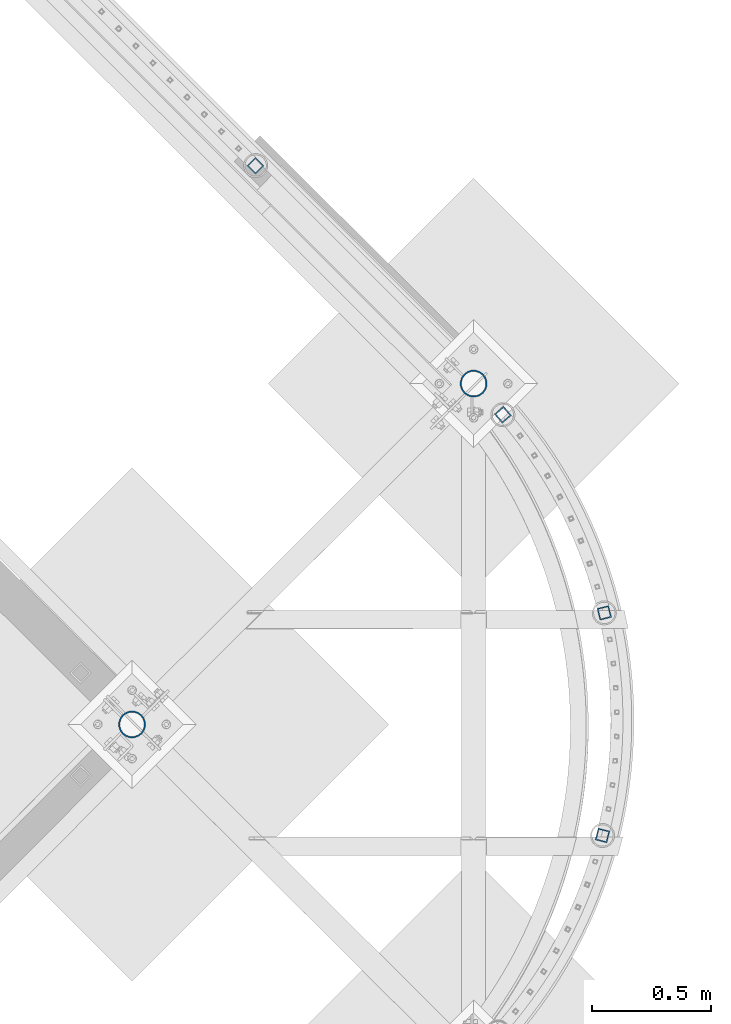
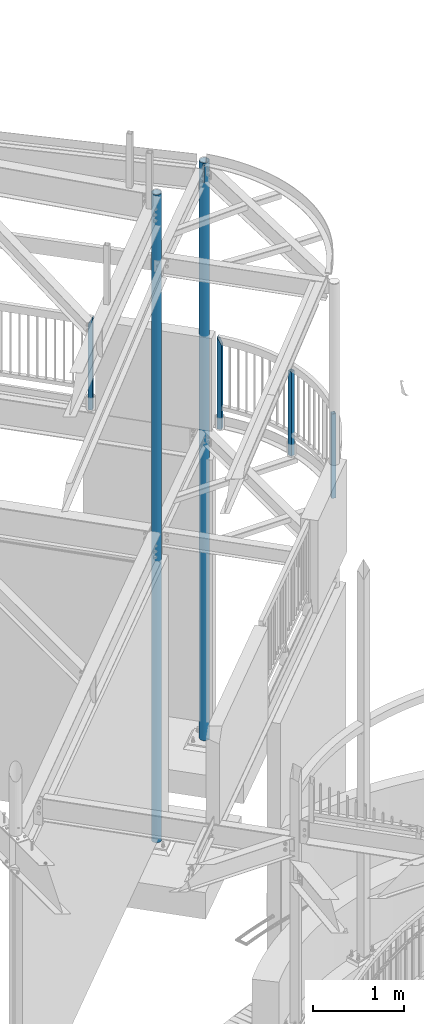
# One storey, part 137 of 975: 6 columns.
"""IFC2X3 building model written with IfcOpenShell, lengths in millimetres."""

from ifc_helpers import new_model, si_unit, frame, origin_with_axes, place, context, subcontext, project, spatial, faceted_brep, material, type_object, element, save


model = new_model("IFC2X3")

# Units and contexts
model_context = context("Model", 3, precision=1e-05, world=origin_with_axes())
body_context = subcontext(model_context, "Body", "Model", "MODEL_VIEW")
ifc_project = project(units=[si_unit("LENGTHUNIT", "METRE", prefix="MILLI"), si_unit("AREAUNIT", "SQUARE_METRE"), si_unit("VOLUMEUNIT", "CUBIC_METRE"), si_unit("MASSUNIT", "GRAM", prefix="KILO"), si_unit("TIMEUNIT", "SECOND"), si_unit("PLANEANGLEUNIT", "RADIAN"), si_unit("SOLIDANGLEUNIT", "STERADIAN"), si_unit("THERMODYNAMICTEMPERATUREUNIT", "DEGREE_CELSIUS"), si_unit("LUMINOUSINTENSITYUNIT", "LUMEN")], contexts=[model_context])

# Site, building, storey
site_placement = place(None, origin_with_axes())
site = spatial("IfcSite", under=ifc_project, at=site_placement, CompositionType="ELEMENT")
building_placement = place(site_placement, origin_with_axes())
building = spatial("IfcBuilding", under=site, at=building_placement, Name="Undefined", CompositionType="ELEMENT")
storey_placement = place(building_placement, origin_with_axes())
storey = spatial("IfcBuildingStorey", under=building, at=storey_placement, Name="Undefined", CompositionType="ELEMENT", Elevation=0.0)

# Columns
ifc_material_1 = material()
column_type_1 = type_object("IfcColumnType", Name="HSS2X2X.188_TUBES", PredefinedType="NOTDEFINED")
for number, where, z_axis, x_axis, name in (
    (1, (36078.7761034097, 11200.4077223262, 3946.52499999334), (0.969531343145851, -0.244967293036851, 0.0), (0.0, 0.0, 1.0), "HANDRAIL"),
    (2, (36086.125656387, 12134.6039135276, 3946.52499999334), (0.968966441574155, 0.247192303891364, 0.0), (0.0, 0.0, 1.0), "HANDRAIL"),
):
    element("IfcColumn", number, at=place(storey_placement, frame(where, z_axis=z_axis, x_axis=x_axis)), inside=storey, type_object=column_type_1, material=ifc_material_1, Name=name, ObjectType="HSS2X2X.188_TUBES", context=body_context, shape_type="Brep", body=[
        faceted_brep([(0.0, 20.6374999999753, -20.6375000000298), (0.0, -20.6375000000153, -20.6375000000153), (1133.47498819963, -20.6374999995132, -20.6374999998079), (1133.47498823965, 20.6375000004919, -20.6374999998552), (0.0, -20.6374999999825, 20.6375000000335), (1133.47498818942, -20.6374999995242, 20.6375000001026), (0.0, 20.6375000000116, 20.6375000000189), (1133.47498822943, 20.6375000004846, 20.6375000000626), (0.0, 25.3999999999724, -25.4000000000342), (0.0, 25.400000000016, 25.4000000000196), (1133.47498823287, 25.4000000004817, 25.4000000000487), (1133.47498824544, 25.4000000004926, -25.3999999998487), (0.0, -25.399999999976, 25.4000000000378), (1133.47498818362, -25.3999999995285, 25.4000000000997), (0.0, -25.400000000016, -25.4000000000196), (1133.47498819619, -25.399999999514, -25.3999999997941)], [[[0, 1, 2, 3]], [[1, 4, 5, 2]], [[4, 6, 7, 5]], [[6, 0, 3, 7]], [[8, 9, 10, 11]], [[9, 12, 13, 10]], [[12, 14, 15, 13]], [[14, 8, 11, 15]], [[13, 15, 11, 10], [5, 7, 3, 2]], [[14, 12, 9, 8], [6, 4, 1, 0]]]),
    ])
column_1_placement = place(storey_placement, frame((35660.5273593798, 12966.2522543199, 3946.52499999334), z_axis=(0.759945520097653, 0.649986774083525, 0.0), x_axis=(0.0, 0.0, 1.0)))
element("IfcColumn", 3, at=column_1_placement, inside=storey, type_object=column_type_1, material=ifc_material_1, Name="HANDRAIL", ObjectType="HSS2X2X.188_TUBES", context=body_context, shape_type="Brep", body=[
    faceted_brep([(0.0, 20.6374999999753, -20.6375000000298), (0.0, -20.6375000000153, -20.6375000000153), (1225.54998821705, -20.6375000000317, -20.6375000000407), (1143.46249827633, 20.6375000000389, -20.6374999999753), (0.0, -20.6374999999825, 20.6375000000335), (1225.08747823559, -20.6375000000371, 20.6374999999825), (0.0, 20.6375000000116, 20.6375000000189), (1142.99998829488, 20.6375000000335, 20.637500000048), (0.0, 25.3999999999724, -25.4000000000342), (0.0, 25.400000000016, 25.4000000000196), (1133.47498823287, 25.4000000004817, 25.4000000000487), (1134.04423135796, 25.4000000000506, -25.3999999999796), (0.0, -25.399999999976, 25.4000000000378), (1234.50574515396, -25.4000000000451, 25.3999999999724), (0.0, -25.400000000016, -25.4000000000196), (1235.07498820807, -25.4000000000397, -25.4000000000597)], [[[0, 1, 2, 3]], [[1, 4, 5, 2]], [[4, 6, 7, 5]], [[6, 0, 3, 7]], [[8, 9, 10, 11]], [[9, 12, 13, 10]], [[12, 14, 15, 13]], [[14, 8, 11, 15]], [[13, 15, 11, 10], [5, 7, 3, 2]], [[14, 12, 9, 8], [6, 4, 1, 0]]]),
])
column_2_placement = place(storey_placement, frame((34622.8180044815, 14011.4024796212, 3937.00001179213), z_axis=(-0.707106781186601, 0.707106781186494, 2.36468622460961e-14), x_axis=(0.0, 0.0, 1.0)))
element("IfcColumn", 4, at=column_2_placement, inside=storey, type_object=column_type_1, material=ifc_material_1, Name="HANDRAIL", ObjectType="HSS2X2X.188_TUBES", context=body_context, shape_type="Brep", body=[
    faceted_brep([(0.0, 20.6374999999753, -20.6375000000298), (0.0, -20.6375000000153, -20.6375000000153), (1235.074979717, -20.6374999999462, -20.6374999999462), (1235.07091767483, 20.6374999999871, -20.6375000000007), (0.0, -20.6374999999825, 20.6375000000335), (1152.52905859553, -20.6375000000121, 20.6375000000007), (0.0, 20.6375000000116, 20.6375000000189), (1152.52497980387, 20.6374999999534, 20.6374999999534), (0.0, 25.3999999999724, -25.4000000000342), (0.0, 25.400000000016, 25.4000000000196), (1143.0, 25.4000000000051, 25.4000000000378), (1244.59503672188, 25.399999999936, -25.3999999999396), (0.0, -25.399999999976, 25.4000000000378), (1143.00493968616, -25.399999999936, 25.399999999936), (0.0, -25.400000000016, -25.4000000000196), (1244.59997970698, -25.399999999936, -25.399999999936)], [[[0, 1, 2, 3]], [[1, 4, 5, 2]], [[4, 6, 7, 5]], [[6, 0, 3, 7]], [[8, 9, 10, 11]], [[9, 12, 13, 10]], [[12, 14, 15, 13]], [[14, 8, 11, 15]], [[13, 15, 11, 10], [5, 7, 3, 2]], [[14, 12, 9, 8], [6, 4, 1, 0]]]),
])
ifc_material_2 = material(Name="STEEL/A53")
column_type_2 = type_object("IfcColumnType", Name="PIPE4STD", PredefinedType="NOTDEFINED")
column_3_placement = place(storey_placement, frame((35537.7749999864, 13096.8750002687, -266.7), z_axis=(-0.707106781186601, 0.707106781186494, 2.36468622460961e-14), x_axis=(0.0, 0.0, 1.0)))
element("IfcColumn", 5, at=column_3_placement, inside=storey, type_object=column_type_2, material=ifc_material_2, Name="COLUMN", ObjectType="PIPE4STD", context=body_context, shape_type="Brep", body=[
    faceted_brep([(7761.2875, -55.0200580201781, -13.4479244010545), (7761.2875, -49.0002580201399, -13.4479244013128), (7513.6375, -49.0002580201399, -13.4479244013128), (7513.6375, -55.0200580201781, -13.4479244010545), (7513.6375, -51.0117393045148, -0.747931395271735), (7513.6375, -57.0315393080673, -0.747931372819949), (7761.2875, -51.0117393045148, -0.747931395271735), (7761.2875, -57.0315393080673, -0.747931372819949), (7761.2875, 49.0002580194123, -13.4479244055565), (7761.2875, 55.0200580193632, -13.4479244058148), (7513.6375, 55.0200580193632, -13.4479244058148), (7513.6375, 49.0002580194123, -13.4479244055565), (7513.6375, 57.0315392406483, -0.747931798301579), (7513.6375, 51.0117392442116, -0.747931775846155), (7761.2875, 57.0315392406483, -0.747931798301579), (7761.2875, 51.0117392442116, -0.747931775846155), (19.0500000000025, 57.1499999999996, 0.0), (19.0500000000025, 54.3528799062678, 17.6603212285299), (7775.575, 54.3528799062333, 17.6603212285772), (7775.575, 57.149999999936, 7.45785655453801e-11), (19.0500000000025, 46.2353212285279, 33.5919271685161), (7775.575, 46.2353212285161, 33.5919271685379), (19.0500000000025, 33.5919271685152, 46.235321228527), (7775.575, 33.5919271685343, 46.2353212285198), (19.0500000000025, 17.6603212285281, 54.3528799062697), (7775.575, 17.66032122857, 54.3528799062333), (19.0500000000025, 0.0, 57.1500000000015), (7775.575, 7.27595761418343e-11, 57.1499999999378), (19.0500000000025, -17.6603212285281, 54.3528799062697), (7775.575, -17.660321228439, 54.352879906186), (19.0500000000025, -33.5919271685152, 46.235321228527), (7775.575, -33.5919271684179, 46.2353212284324), (19.0500000000025, -46.2353212285279, 33.5919271685161), (7775.575, -46.2353212284361, 33.5919271684161), (19.0500000000025, -54.3528799062678, 17.6603212285299), (7775.575, -54.3528799061896, 17.660321228439), (19.0500000000025, -57.1499999999996, 0.0), (7775.575, -57.149999999936, -7.27595761418343e-11), (19.0500000000025, 46.2353212285279, -33.5919271685161), (19.0500000000025, 54.3528799062678, -17.6603212285299), (7775.575, 54.3528799061824, -17.6603212284354), (7775.575, 46.2353212284288, -33.5919271684143), (19.0500000000025, 33.5919271685152, -46.235321228527), (7775.575, 33.5919271684106, -46.2353212284306), (19.0500000000025, 17.6603212285281, -54.3528799062697), (7775.575, 17.6603212284317, -54.3528799061824), (19.0500000000025, 0.0, -57.1500000000015), (7775.575, -7.27595761418343e-11, -57.149999999936), (19.0500000000025, -17.6603212285281, -54.3528799062697), (7775.575, -17.6603212285772, -54.3528799062315), (19.0500000000025, -33.5919271685152, -46.235321228527), (7775.575, -33.5919271685416, -46.2353212285179), (19.0500000000025, -46.2353212285279, -33.5919271685161), (7775.575, -46.2353212285234, -33.5919271685361), (19.0500000000025, -54.3528799062678, -17.6603212285299), (7775.575, -54.3528799062333, -17.6603212285754), (19.0500000000025, -48.6277098894743, -15.8001007257917), (19.0500000000025, -41.3652007257897, -30.0535775067656), (19.0500000000025, -30.0535775067647, -41.3652007257915), (19.0500000000025, -15.8001007257899, -48.6277098894752), (19.0500000000025, 0.0, -51.1301999999996), (19.0500000000025, 15.8001007257899, -48.6277098894752), (19.0500000000025, 30.0535775067647, -41.3652007257915), (19.0500000000025, 41.3652007257897, -30.0535775067656), (19.0500000000025, 48.6277098894743, -15.8001007257917), (19.0500000000025, 51.1301999999996, 0.0), (19.0500000000025, 48.6277098894743, 15.8001007257917), (19.0500000000025, 41.3652007257897, 30.0535775067656), (19.0500000000025, 30.0535775067647, 41.3652007257915), (19.0500000000025, 15.8001007257899, 48.6277098894752), (19.0500000000025, 0.0, 51.1301999999996), (19.0500000000025, -15.8001007257899, 48.6277098894752), (19.0500000000025, -30.0535775067647, 41.3652007257915), (19.0500000000025, -41.3652007257897, 30.0535775067656), (19.0500000000025, -48.6277098894743, 15.8001007257917), (19.0500000000025, -51.1301999999996, 0.0), (7775.575, -51.1301999999414, -6.3664629124105e-11), (7775.575, -48.6277098894425, -15.8001007258372), (7775.575, -41.3652007257842, -30.0535775067856), (7775.575, -30.053577506791, -41.3652007257788), (7775.575, -15.8001007258426, -48.627709889437), (7775.575, -7.27595761418343e-11, -51.1301999999396), (7775.575, 15.8001007257044, -48.6277098893952), (7775.575, 30.0535775066746, -41.365200725706), (7775.575, 41.3652007257042, -30.0535775066783), (7775.575, 48.6277098893916, -15.8001007257044), (7775.575, 51.1301999999414, 6.73026079311967e-11), (7775.575, 48.6277098894352, 15.800100725839), (7775.575, 41.365200725777, 30.0535775067874), (7775.575, 30.0535775067838, 41.3652007257806), (7775.575, 15.8001007258354, 48.6277098894388), (7775.575, 6.54836185276508e-11, 51.1301999999432), (7775.575, -15.8001007257117, 48.6277098894025), (7775.575, -30.0535775066819, 41.3652007257078), (7775.575, -41.3652007257115, 30.0535775066801), (7775.575, -48.6277098893988, 15.8001007257117)], [[[0, 1, 2, 3]], [[3, 2, 4, 5]], [[5, 4, 6, 7]], [[7, 6, 1, 0]], [[8, 9, 10, 11]], [[11, 10, 12, 13]], [[13, 12, 14, 15]], [[15, 14, 9, 8]], [[16, 17, 18, 19]], [[17, 20, 21, 18]], [[20, 22, 23, 21]], [[22, 24, 25, 23]], [[24, 26, 27, 25]], [[26, 28, 29, 27]], [[28, 30, 31, 29]], [[30, 32, 33, 31]], [[32, 34, 35, 33]], [[34, 36, 37, 35]], [[38, 39, 40, 41]], [[42, 38, 41, 43]], [[44, 42, 43, 45]], [[46, 44, 45, 47]], [[48, 46, 47, 49]], [[50, 48, 49, 51]], [[52, 50, 51, 53]], [[54, 52, 53, 55]], [[36, 54, 55, 37], [3, 5, 7, 0]], [[34, 32, 30, 28, 26, 24, 22, 20, 17, 16, 39, 38, 42, 44, 46, 48, 50, 52, 54, 36], [56, 57, 58, 59, 60, 61, 62, 63, 64, 65, 66, 67, 68, 69, 70, 71, 72, 73, 74, 75]], [[56, 75, 76, 77], [2, 1, 6, 4]], [[57, 56, 77, 78]], [[58, 57, 78, 79]], [[59, 58, 79, 80]], [[60, 59, 80, 81]], [[61, 60, 81, 82]], [[62, 61, 82, 83]], [[63, 62, 83, 84]], [[64, 63, 84, 85]], [[65, 64, 85, 86], [11, 13, 15, 8]], [[66, 65, 86, 87]], [[67, 66, 87, 88]], [[68, 67, 88, 89]], [[69, 68, 89, 90]], [[70, 69, 90, 91]], [[71, 70, 91, 92]], [[72, 71, 92, 93]], [[73, 72, 93, 94]], [[74, 73, 94, 95]], [[75, 74, 95, 76]], [[53, 51, 49, 47, 45, 43, 41, 40, 19, 18, 21, 23, 25, 27, 29, 31, 33, 35, 37, 55], [94, 93, 92, 91, 90, 89, 88, 87, 86, 85, 84, 83, 82, 81, 80, 79, 78, 77, 76, 95]], [[39, 16, 19, 40], [10, 9, 14, 12]]]),
])
column_4_placement = place(storey_placement, frame((34104.2625, 11666.5375, -266.7), z_axis=(-0.707106781186601, 0.707106781186494, 2.36468622460961e-14), x_axis=(0.0, 0.0, 1.0)))
element("IfcColumn", 6, at=column_4_placement, inside=storey, type_object=column_type_2, material=ifc_material_2, Name="COLUMN", ObjectType="PIPE4STD", context=body_context, shape_type="Brep", body=[
    faceted_brep([(4179.88750000005, 3.02413066930603, -50.6512247564024), (4179.88750000005, 3.00627923796856, -56.673852145359), (3859.21249999986, 3.00627923796856, -56.673852145359), (3859.21249999986, 3.02413066930603, -50.6512247564024), (3859.21249999986, 15.7123000085267, -54.661416156845), (3859.21249999986, 15.8001007257117, -48.6277098894025), (4179.88750000005, 15.7123000085267, -54.661416156845), (4179.88750000005, 15.7301848925927, -48.6275026546518), (19.0500000000025, 17.6603212285281, -54.3528799062697), (19.0500000000025, 33.5919271685152, -46.235321228527), (8715.37500012522, 33.5919271684215, -46.2353212284343), (8715.37500012522, 17.6603212284463, -54.352879906186), (19.0500000000025, 46.2353212285279, -33.5919271685161), (8715.37500012522, 46.2353212284361, -33.5919271684179), (19.0500000000025, 54.3528799062678, -17.6603212285299), (8715.37500012522, 54.3528799061896, -17.660321228439), (19.0500000000025, 57.1499999999996, 0.0), (8715.37500012522, 57.1499999999432, 7.09405867382884e-11), (19.0500000000025, 54.3528799062678, 17.6603212285299), (8715.37500012522, 54.3528799062406, 17.6603212285736), (19.0500000000025, 46.2353212285279, 33.5919271685161), (8715.37500012522, 46.2353212285234, 33.5919271685343), (19.0500000000025, 33.5919271685152, 46.235321228527), (8715.37500012522, 33.5919271685416, 46.2353212285161), (19.0500000000025, 17.6603212285281, 54.3528799062697), (8715.37500012522, 17.6603212285845, 54.3528799062296), (19.0500000000025, 0.0, 57.1500000000015), (8715.37500012522, 8.00355337560177e-11, 57.1499999999342), (3859.21249999986, 16.0361874338414, 54.6101174283176), (4182.08725268, 16.0361874338414, 54.6101174283176), (4182.08725268, 3.34209102889872, 56.6206647828258), (3859.21249999986, 3.34209102889872, 56.6206647828258), (19.0500000000025, -17.6603212285281, 54.3528799062697), (8715.37500012522, -17.6603212284317, 54.3528799061824), (19.0500000000025, -33.5919271685152, 46.235321228527), (8715.37500012522, -33.5919271684106, 46.2353212284288), (19.0500000000025, -46.2353212285279, 33.5919271685161), (8715.37500012522, -46.2353212284252, 33.5919271684124), (19.0500000000025, -54.3528799062678, 17.6603212285299), (8715.37500012522, -54.3528799061751, 17.6603212284354), (19.0500000000025, -57.1499999999996, 0.0), (8715.37500012522, -57.1499999999287, -7.6397554948926e-11), (19.0500000000025, -17.6603212285281, -54.3528799062697), (19.0500000000025, 0.0, -57.1500000000015), (8715.37500012522, -6.54836185276508e-11, -57.1499999999396), (8715.37500012522, -17.66032122857, -54.3528799062351), (19.0500000000025, -33.5919271685152, -46.235321228527), (8715.37500012522, -33.5919271685307, -46.2353212285216), (19.0500000000025, -46.2353212285279, -33.5919271685161), (8715.37500012522, -46.2353212285125, -33.5919271685398), (19.0500000000025, -54.3528799062678, -17.6603212285299), (8715.37500012522, -54.352879906226, -17.6603212285791), (19.0500000000025, -48.6277098894743, -15.8001007257917), (19.0500000000025, -41.3652007257897, -30.0535775067656), (19.0500000000025, -30.0535775067647, -41.3652007257915), (19.0500000000025, -15.8001007257899, -48.6277098894752), (19.0500000000025, 0.0, -51.1301999999996), (19.0500000000025, 15.8001007257899, -48.6277098894752), (19.0500000000025, 30.0535775067647, -41.3652007257915), (19.0500000000025, 41.3652007257897, -30.0535775067656), (19.0500000000025, 48.6277098894743, -15.8001007257917), (19.0500000000025, 51.1301999999996, 0.0), (19.0500000000025, 48.6277098894743, 15.8001007257917), (19.0500000000025, 41.3652007257897, 30.0535775067656), (19.0500000000025, 30.0535775067647, 41.3652007257915), (19.0500000000025, 15.8001007257899, 48.6277098894752), (19.0500000000025, 0.0, 51.1301999999996), (19.0500000000025, -15.8001007257899, 48.6277098894752), (19.0500000000025, -30.0535775067647, 41.3652007257915), (19.0500000000025, -41.3652007257897, 30.0535775067656), (19.0500000000025, -48.6277098894743, 15.8001007257917), (19.0500000000025, -51.1301999999996, 0.0), (8715.37500012522, -51.1301999999341, -6.73026079311967e-11), (8715.37500012522, -48.6277098894316, -15.8001007258408), (8715.37500012522, -41.3652007257733, -30.0535775067892), (8715.37500012522, -30.0535775067801, -41.3652007257824), (8715.37500012522, -15.8001007258317, -48.6277098894407), (8715.37500012522, -5.82076609134674e-11, -51.1301999999432), (8715.37500012522, 15.8001007257117, -48.6277098894025), (8715.37500012522, 30.0535775066855, -41.3652007257097), (8715.37500012522, 41.3652007257115, -30.0535775066819), (8715.37500012522, 48.6277098894061, -15.8001007257117), (8715.37500012522, 51.1301999999487, 6.3664629124105e-11), (8715.37500012522, 48.6277098894425, 15.8001007258354), (8715.37500012522, 41.3652007257842, 30.0535775067838), (8715.37500012522, 30.053577506791, 41.365200725777), (8715.37500012522, 15.8001007258426, 48.6277098894352), (4182.08725268, 15.8001007258426, 48.6277098894352), (3859.21249999986, 15.8001007258426, 48.6277098894352), (3859.21249999986, 3.32425635079562, 50.6036895183352), (4182.08725268, 3.32425635079562, 50.6036895183352), (8715.37500012522, 7.27595761418343e-11, 51.1301999999396), (8715.37500012522, -15.8001007256971, 48.6277098893952), (8715.37500012522, -30.0535775066746, 41.3652007257042), (8715.37500012522, -41.3652007257006, 30.0535775066764), (8715.37500012522, -48.6277098893916, 15.8001007257044)], [[[0, 1, 2, 3]], [[3, 2, 4, 5]], [[5, 4, 6, 7]], [[7, 6, 1, 0]], [[8, 9, 10, 11]], [[9, 12, 13, 10]], [[12, 14, 15, 13]], [[14, 16, 17, 15]], [[16, 18, 19, 17]], [[18, 20, 21, 19]], [[20, 22, 23, 21]], [[22, 24, 25, 23]], [[24, 26, 27, 25], [28, 29, 30, 31]], [[26, 32, 33, 27]], [[32, 34, 35, 33]], [[34, 36, 37, 35]], [[36, 38, 39, 37]], [[38, 40, 41, 39]], [[42, 43, 44, 45]], [[46, 42, 45, 47]], [[48, 46, 47, 49]], [[50, 48, 49, 51]], [[40, 50, 51, 41]], [[38, 36, 34, 32, 26, 24, 22, 20, 18, 16, 14, 12, 9, 8, 43, 42, 46, 48, 50, 40], [52, 53, 54, 55, 56, 57, 58, 59, 60, 61, 62, 63, 64, 65, 66, 67, 68, 69, 70, 71]], [[52, 71, 72, 73]], [[53, 52, 73, 74]], [[54, 53, 74, 75]], [[55, 54, 75, 76]], [[56, 55, 76, 77]], [[3, 5, 57, 56, 77, 78, 7, 0]], [[78, 79, 58, 57, 5, 7]], [[59, 58, 79, 80]], [[60, 59, 80, 81]], [[61, 60, 81, 82]], [[62, 61, 82, 83]], [[63, 62, 83, 84]], [[64, 63, 84, 85]], [[65, 64, 85, 86, 87, 88]], [[28, 88, 87, 29]], [[31, 89, 88, 28]], [[30, 90, 89, 31]], [[29, 87, 90, 30]], [[86, 91, 66, 65, 88, 89, 90, 87]], [[67, 66, 91, 92]], [[68, 67, 92, 93]], [[69, 68, 93, 94]], [[70, 69, 94, 95]], [[71, 70, 95, 72]], [[49, 47, 45, 44, 11, 10, 13, 15, 17, 19, 21, 23, 25, 27, 33, 35, 37, 39, 41, 51], [94, 93, 92, 91, 86, 85, 84, 83, 82, 81, 80, 79, 78, 77, 76, 75, 74, 73, 72, 95]], [[43, 8, 11, 44], [2, 1, 6, 4]]]),
])

save(model, "model.ifc")
